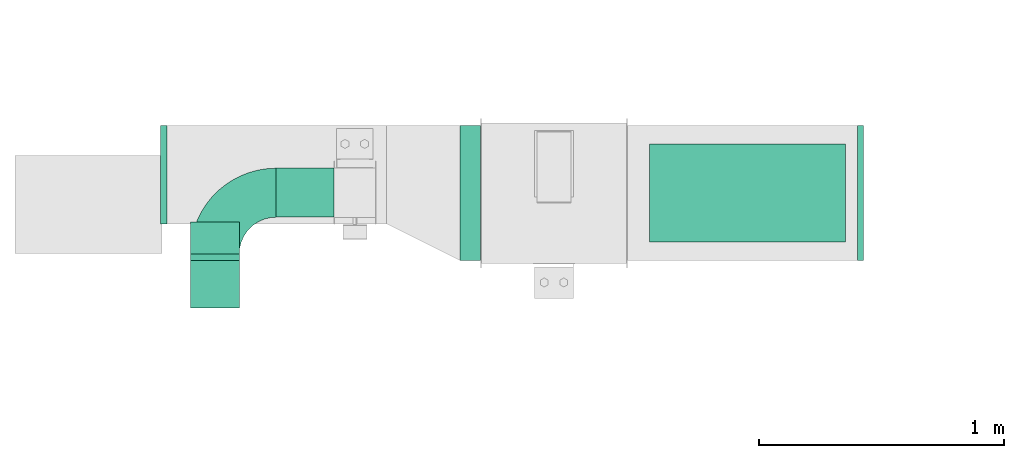
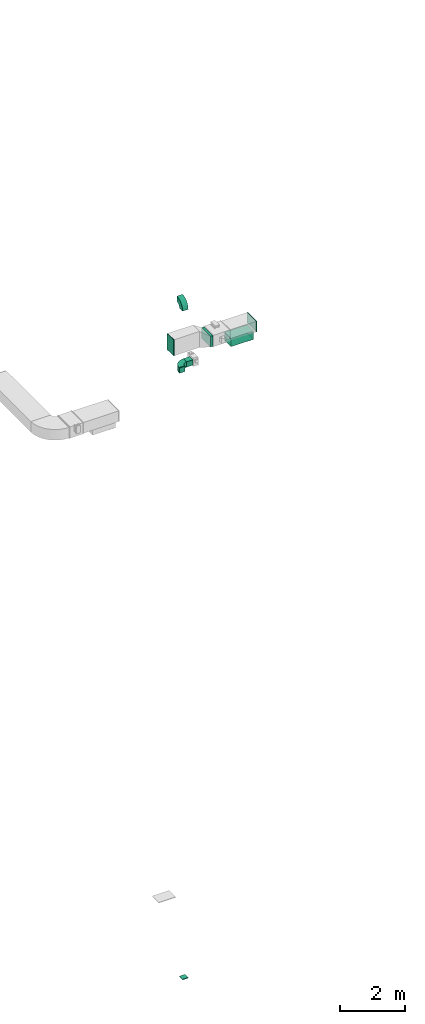
# One storey, part 3 of 9: 7 flow fittings, 3 flow segments, 1 flow terminal.
"""IFC2X3 building model written with IfcOpenShell, lengths in millimetres."""

from ifc_helpers import new_model, entity, si_unit, converted_unit, derived_unit, direction, frame, frame_2d, origin, origin_2d_with_axis, place, context, subcontext, project, spatial, polyline, circle_curve, parameter, trimmed, segment, composite_curve, rectangle, outline, extrude, source, transform, mapped, material, type_object, type_shapes, element, save


model = new_model("IFC2X3")

# Units and contexts
model_context = context("Model", 3, precision=0.01, world=origin(), true_north=direction((6.12303176911189e-17, 1.0)))
body_context = subcontext(model_context, "Body", "Model", "MODEL_VIEW")
ifc_project = project(units=[si_unit("LENGTHUNIT", "METRE", prefix="MILLI"), si_unit("AREAUNIT", "SQUARE_METRE"), si_unit("VOLUMEUNIT", "CUBIC_METRE"), converted_unit("PLANEANGLEUNIT", "DEGREE", entity("IfcRatioMeasure", 0.0174532925199433), si_unit("PLANEANGLEUNIT", "RADIAN"), dimensions=[0, 0, 0, 0, 0, 0, 0]), si_unit("MASSUNIT", "GRAM", prefix="KILO"), derived_unit("MASSDENSITYUNIT", [(si_unit("MASSUNIT", "GRAM", prefix="KILO"), 1), (si_unit("LENGTHUNIT", "METRE"), -3)]), derived_unit("MOMENTOFINERTIAUNIT", [(si_unit("LENGTHUNIT", "METRE"), 4)]), si_unit("TIMEUNIT", "SECOND"), si_unit("FREQUENCYUNIT", "HERTZ"), si_unit("THERMODYNAMICTEMPERATUREUNIT", "DEGREE_CELSIUS"), derived_unit("THERMALTRANSMITTANCEUNIT", [(si_unit("MASSUNIT", "GRAM", prefix="KILO"), 1), (si_unit("THERMODYNAMICTEMPERATUREUNIT", "KELVIN"), -1), (si_unit("TIMEUNIT", "SECOND"), -3)]), derived_unit("VOLUMETRICFLOWRATEUNIT", [(si_unit("LENGTHUNIT", "METRE"), 3), (si_unit("TIMEUNIT", "SECOND"), -1)]), derived_unit("MASSFLOWRATEUNIT", [(si_unit("MASSUNIT", "GRAM", prefix="KILO"), 1), (si_unit("TIMEUNIT", "SECOND"), -1)]), derived_unit("ROTATIONALFREQUENCYUNIT", [(si_unit("TIMEUNIT", "SECOND"), -1)]), si_unit("ELECTRICCURRENTUNIT", "AMPERE"), si_unit("ELECTRICVOLTAGEUNIT", "VOLT"), si_unit("POWERUNIT", "WATT"), si_unit("FORCEUNIT", "NEWTON", prefix="KILO"), si_unit("ILLUMINANCEUNIT", "LUX"), si_unit("LUMINOUSFLUXUNIT", "LUMEN"), si_unit("LUMINOUSINTENSITYUNIT", "CANDELA"), derived_unit("USERDEFINED", [(si_unit("MASSUNIT", "GRAM", prefix="KILO"), -1), (si_unit("LENGTHUNIT", "METRE"), -2), (si_unit("TIMEUNIT", "SECOND"), 3), (si_unit("LUMINOUSFLUXUNIT", "LUMEN"), 1)]), derived_unit("LINEARVELOCITYUNIT", [(si_unit("LENGTHUNIT", "METRE"), 1), (si_unit("TIMEUNIT", "SECOND"), -1)]), si_unit("PRESSUREUNIT", "PASCAL"), derived_unit("USERDEFINED", [(si_unit("LENGTHUNIT", "METRE"), -2), (si_unit("MASSUNIT", "GRAM", prefix="KILO"), 1), (si_unit("TIMEUNIT", "SECOND"), -2)]), derived_unit("LINEARFORCEUNIT", [(si_unit("MASSUNIT", "GRAM", prefix="KILO"), 1), (si_unit("LENGTHUNIT", "METRE"), 1), (si_unit("TIMEUNIT", "SECOND"), -2), (si_unit("LENGTHUNIT", "METRE"), -1)]), derived_unit("PLANARFORCEUNIT", [(si_unit("MASSUNIT", "GRAM", prefix="KILO"), 1), (si_unit("LENGTHUNIT", "METRE"), 1), (si_unit("TIMEUNIT", "SECOND"), -2), (si_unit("LENGTHUNIT", "METRE"), -2)])], contexts=[model_context])

# Site, building, storey
site_placement = place(None, frame((0.0, -0.00077364408347762, 0.0)))
site = spatial("IfcSite", under=ifc_project, at=site_placement, CompositionType="ELEMENT")
building_placement = place(site_placement, origin())
building = spatial("IfcBuilding", under=site, at=building_placement, CompositionType="ELEMENT")
storey_placement = place(building_placement, frame((0.0, 0.0, 24000.0)))
storey = spatial("IfcBuildingStorey", under=building, at=storey_placement, CompositionType="ELEMENT", Elevation=24000.0)

# Flow segments
duct_segment_type = type_object("IfcDuctSegmentType", PredefinedType="NOTDEFINED")
flow_segment_1_placement = place(storey_placement, frame((11245.7694963104, 14444.0835453812, 3200.0)))
element("IfcFlowSegment", 1, at=flow_segment_1_placement, inside=storey, type_object=duct_segment_type, context=body_context, shape_type="SweptSolid", body=[
    extrude(rectangle(XDim=82.7176589595067, YDim=550.000000000001, at=frame_2d((-1.08357767203415e-12, 0.0), x_axis=(1.0, 0.0))), frame((41.3588294797544, 275.0, 0.0)), (0.0, 0.0, 1.0), 399.999999999996),
])
flow_segment_2_placement = place(storey_placement, frame((12017.1283257901, 14519.0835453812, 2900.0)))
element("IfcFlowSegment", 2, at=flow_segment_2_placement, inside=storey, type_object=duct_segment_type, context=body_context, shape_type="SweptSolid", body=[
    extrude(rectangle(XDim=800.0, YDim=400.0, at=frame_2d((0.0, -2.17426077142591e-12), x_axis=(1.0, 0.0))), frame((400.0, 200.0, 0.0)), (0.0, 0.0, 1.0), 280.000000000006),
])
flow_segment_3_placement = place(storey_placement, frame((10494.7174683872, 14620.8402530396, 2600.0)))
element("IfcFlowSegment", 3, at=flow_segment_3_placement, inside=storey, type_object=duct_segment_type, context=body_context, shape_type="SweptSolid", body=[
    extrude(rectangle(XDim=236.407017077476, YDim=200.0, at=frame_2d((0.0, -1.08713038571295e-12), x_axis=(1.0, 0.0))), frame((118.203508538738, 100.0, 0.0), z_axis=(0.0, 0.0, 1.0), x_axis=(-1.0, 0.0, 0.0)), (0.0, 0.0, 1.0), 199.999999999998),
])

# Flow fittings
ifc_material_1 = material()
duct_fitting_type_1 = type_object("IfcDuctFittingType", PredefinedType="NOTDEFINED", material=ifc_material_1)
shared_shape_1 = source(origin(), body_context, "Body", "SweptSolid", [
    extrude(rectangle(XDim=800.0, YDim=26.096, at=frame_2d((-5.6843418860808e-14, 0.0), x_axis=(1.0, 0.0))), frame((6.95199999999999, 0.0, -200.0), z_axis=(0.0, 0.0, 1.0), x_axis=(0.0, -1.0, 0.0)), (0.0, 0.0, 1.0), 400.0),
])
type_shapes(duct_fitting_type_1, [shared_shape_1])
flow_fitting_1_placement = place(storey_placement, frame((12417.1283257901, 14719.0835453812, 3200.0), z_axis=(0.0, 1.0, 0.0), x_axis=(0.0, 0.0, -1.0)))
element("IfcFlowFitting", 4, at=flow_fitting_1_placement, inside=storey, type_object=duct_fitting_type_1, material=ifc_material_1, context=body_context, shape_type="MappedRepresentation", body=[
    mapped(shared_shape_1, transform((0.0, 0.0, 0.0), scale=1.0)),
])
duct_fitting_type_2 = type_object("IfcDuctFittingType", PredefinedType="NOTDEFINED", material=ifc_material_1)
shared_shape_2 = source(origin(), body_context, "Body", "SweptSolid", [
    extrude(rectangle(XDim=24.9999999999999, YDim=550.0, at=frame_2d((-2.28261853862932e-13, 0.0), x_axis=(1.0, 0.0))), frame((12.500000000006, 0.0, -200.0)), (0.0, 0.0, 1.0), 400.0),
])
type_shapes(duct_fitting_type_2, [shared_shape_2])
flow_fitting_2_placement = place(storey_placement, frame((12865.7694963104, 14719.0835453812, 3400.0)))
element("IfcFlowFitting", 5, at=flow_fitting_2_placement, inside=storey, type_object=duct_fitting_type_2, material=ifc_material_1, context=body_context, shape_type="MappedRepresentation", body=[
    mapped(shared_shape_2, transform((0.0, 0.0, 0.0), scale=1.0)),
])
duct_fitting_type_3 = type_object("IfcDuctFittingType", PredefinedType="NOTDEFINED", material=ifc_material_1)
shared_shape_3 = source(origin(), body_context, "Body", "SweptSolid", [
    extrude(rectangle(XDim=600.0, YDim=26.096, at=origin_2d_with_axis()), frame((6.95199999999999, 0.0, -200.0), z_axis=(0.0, 0.0, 1.0), x_axis=(0.0, -1.0, 0.0)), (0.0, 0.0, 1.0), 400.0),
])
type_shapes(duct_fitting_type_3, [shared_shape_3])
flow_fitting_3_placement = place(storey_placement, frame((10029.7340134019, 14794.0835453813, 3500.0), z_axis=(0.0, -1.0, 0.0), x_axis=(1.0, 0.0, 0.0)))
element("IfcFlowFitting", 6, at=flow_fitting_3_placement, inside=storey, type_object=duct_fitting_type_3, material=ifc_material_1, context=body_context, shape_type="MappedRepresentation", body=[
    mapped(shared_shape_3, transform((0.0, 0.0, 0.0), scale=1.0)),
])

# Flow terminal
ifc_material_2 = material()
air_terminal_type = type_object("IfcAirTerminalType", PredefinedType="NOTDEFINED", material=ifc_material_2)
shared_shape_4 = source(origin(), body_context, "Body", "SweptSolid", [
    extrude(rectangle(XDim=4.0, YDim=799.999999999999, at=origin_2d_with_axis()), frame((0.0, -2.0, -200.0), z_axis=(0.0, 0.0, 1.0), x_axis=(0.0, 1.0, 0.0)), (0.0, 0.0, 1.0), 400.000000000005),
])
type_shapes(air_terminal_type, [shared_shape_4])
flow_terminal_placement = place(storey_placement, frame((12417.1283257901, 14719.0835453812, 2900.0), z_axis=(0.0, 1.0, 0.0), x_axis=(-1.0, 0.0, 0.0)))
element("IfcFlowTerminal", 7, at=flow_terminal_placement, inside=storey, type_object=air_terminal_type, material=ifc_material_2, context=body_context, shape_type="MappedRepresentation", body=[
    mapped(shared_shape_4, transform((0.0, 0.0, 0.0), scale=1.0)),
])

# Flow fittings
duct_fitting_type_4 = type_object("IfcDuctFittingType", PredefinedType="NOTDEFINED", material=ifc_material_1)
shared_shape_5 = source(origin(), body_context, "Body", "SweptSolid", [
    extrude(rectangle(XDim=24.9999999999999, YDim=200.0, at=frame_2d((-8.34887714518118e-14, 1.4210854715202e-14), x_axis=(1.0, 0.0))), frame((12.5000000000062, 0.0, -100.0)), (0.0, 0.0, 1.0), 200.0),
])
type_shapes(duct_fitting_type_4, [shared_shape_5])
flow_fitting_4_placement = place(storey_placement, frame((10244.7174683872, 14350.8402530397, -20000.0), z_axis=(0.0, -1.0, 0.0), x_axis=(0.0, 0.0, -1.0)))
element("IfcFlowFitting", 8, at=flow_fitting_4_placement, inside=storey, type_object=duct_fitting_type_4, material=ifc_material_1, context=body_context, shape_type="MappedRepresentation", body=[
    mapped(shared_shape_5, transform((0.0, 0.0, 0.0), scale=1.0)),
])
duct_fitting_type_5 = type_object("IfcDuctFittingType", PredefinedType="NOTDEFINED", material=ifc_material_1)
shared_shape_6 = source(origin(), body_context, "Body", "SweptSolid", [
    extrude(outline(composite_curve([segment(polyline([(-225.0, -125.0), (-25.0, -125.0)]), True, "CONTINUOUS"), segment(trimmed(circle_curve(frame_2d((125.0, -125.0), x_axis=(0.0, 1.0)), 150.0), [parameter(0.0)], [parameter(90.0000000000001)], True, "PARAMETER"), False, "CONTINUOUS"), segment(polyline([(125.0, 25.0), (125.0, 225.0)]), True, "CONTINUOUS"), segment(trimmed(circle_curve(frame_2d((125.0, -125.0), x_axis=(0.0, 1.0)), 350.0), [parameter(0.0)], [parameter(90.0000000000001)], True, "PARAMETER"), True, "CONTINUOUS")], self_intersect=False)), frame((-125.0, 125.0, -100.0), z_axis=(0.0, 0.0, 1.0), x_axis=(-1.0, 0.0, 0.0)), (0.0, 0.0, 1.0), 200.0),
])
type_shapes(duct_fitting_type_5, [shared_shape_6])
for number, where, z_axis, x_axis in (
    (9, (10244.7174683872, 14720.8402530396, 2700.0), (0.0, 0.0, 1.0), (-1.0, 0.0, 0.0)),
    (10, (10244.7174683872, 14350.8402530397, 5300.0), (-1.0, 0.0, 0.0), (0.0, 0.0, 1.0)),
):
    element("IfcFlowFitting", number, at=place(storey_placement, frame(where, z_axis=z_axis, x_axis=x_axis)), inside=storey, type_object=duct_fitting_type_5, material=ifc_material_1, context=body_context, shape_type="MappedRepresentation", body=[
        mapped(shared_shape_6, transform((0.0, 0.0, 0.0), scale=1.0)),
    ])
duct_fitting_type_6 = type_object("IfcDuctFittingType", PredefinedType="NOTDEFINED", material=ifc_material_1)
shared_shape_7 = source(origin(), body_context, "Body", "SweptSolid", [
    extrude(rectangle(XDim=200.0, YDim=26.096, at=frame_2d((-1.4210854715202e-14, 0.0), x_axis=(1.0, 0.0))), frame((6.95199999999999, 0.0, -100.0), z_axis=(0.0, 0.0, 1.0), x_axis=(0.0, -1.0, 0.0)), (0.0, 0.0, 1.0), 200.0),
])
type_shapes(duct_fitting_type_6, [shared_shape_7])
flow_fitting_5_placement = place(storey_placement, frame((10244.7174683872, 14450.8402530396, 2700.0), z_axis=(1.0, 0.0, 0.0), x_axis=(0.0, 1.0, 0.0)))
element("IfcFlowFitting", 11, at=flow_fitting_5_placement, inside=storey, type_object=duct_fitting_type_6, material=ifc_material_1, context=body_context, shape_type="MappedRepresentation", body=[
    mapped(shared_shape_7, transform((0.0, 0.0, 0.0), scale=1.0)),
])

save(model, "model.ifc")
